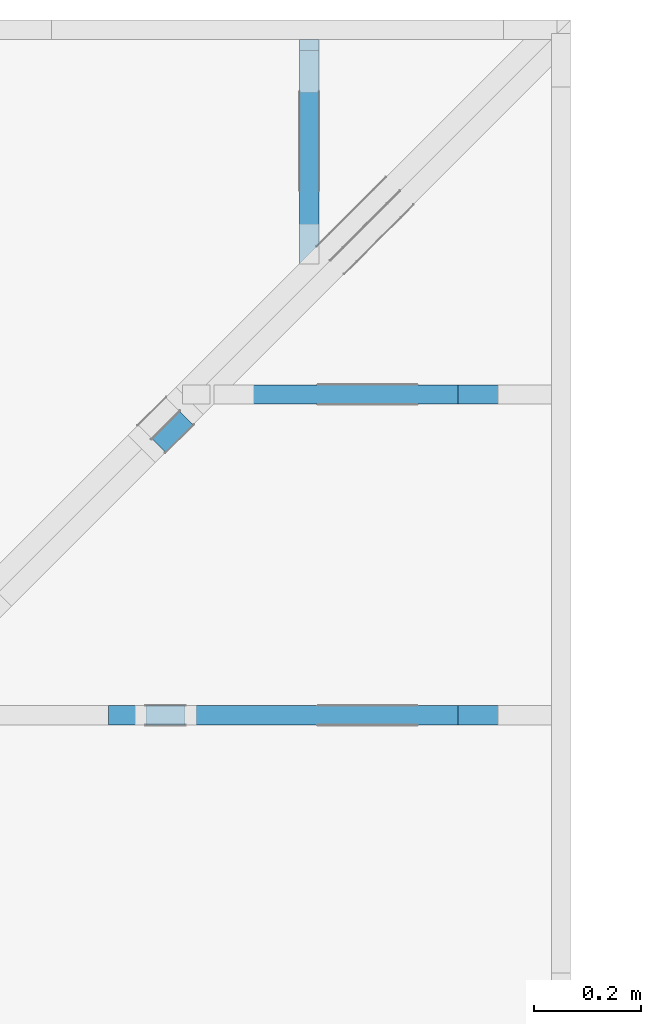
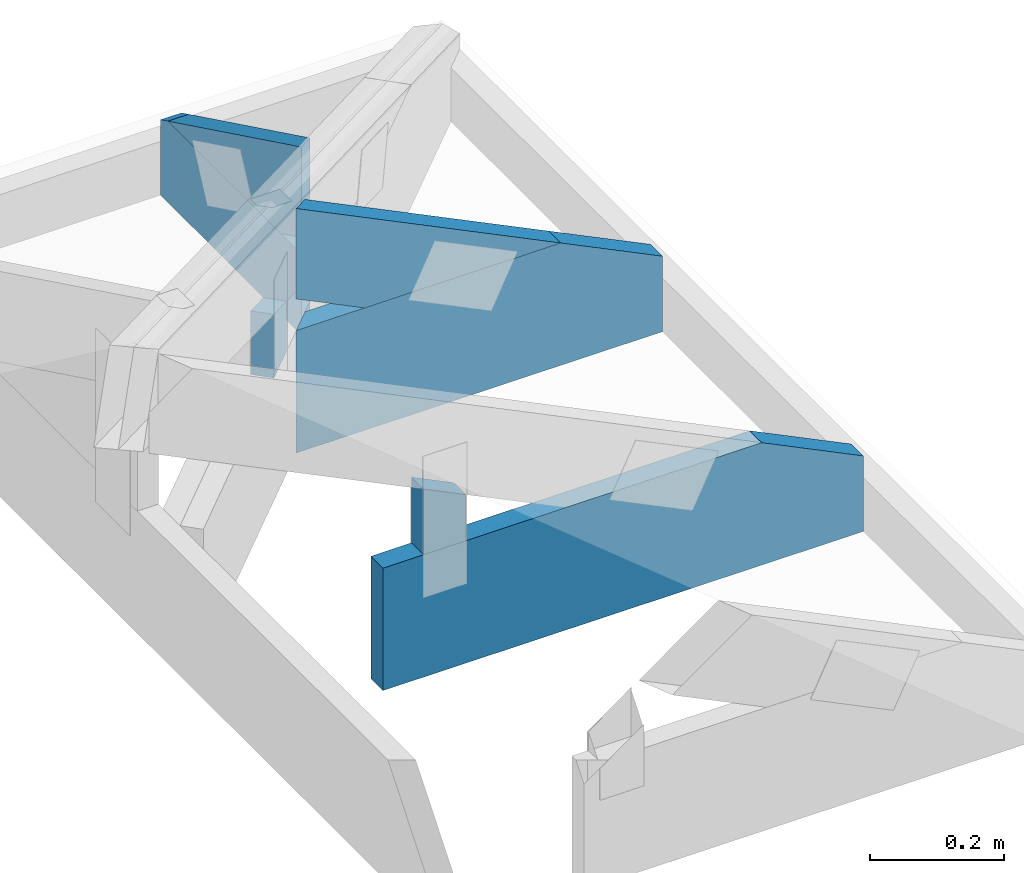
# One storey, part 53 of 159: 7 members, 4 elements without a shape of their own.
"""IFC2X3 building model written with IfcOpenShell, lengths in millimetres."""

from ifc_helpers import new_model, si_unit, frame, origin, origin_with_axes, origin_2d, place, context, project, spatial, faceted_brep, element, aggregate, save


model = new_model("IFC2X3")

# Units and contexts
model_context = context("Model", 3, precision=1e-05, world=origin())
plan_context = context("Plan", 2, precision=1e-05, world=origin_2d())
ifc_project = project(units=[si_unit("LENGTHUNIT", "METRE", prefix="MILLI"), si_unit("AREAUNIT", "SQUARE_METRE"), si_unit("VOLUMEUNIT", "CUBIC_METRE"), si_unit("SOLIDANGLEUNIT", "STERADIAN"), si_unit("PLANEANGLEUNIT", "RADIAN"), si_unit("MASSUNIT", "GRAM"), si_unit("TIMEUNIT", "SECOND"), si_unit("THERMODYNAMICTEMPERATUREUNIT", "DEGREE_CELSIUS"), si_unit("LUMINOUSINTENSITYUNIT", "LUMEN")], contexts=[model_context, plan_context])

# Site, building, storey
site_placement = place(None, origin_with_axes())
site = spatial("IfcSite", under=ifc_project, at=site_placement, CompositionType="ELEMENT")
building_placement = place(site_placement, origin_with_axes())
building = spatial("IfcBuilding", under=site, at=building_placement, Name="Plan 1", CompositionType="ELEMENT")
storey_placement = place(building_placement, origin_with_axes())
storey = spatial("IfcBuildingStorey", under=building, at=storey_placement, Name="Etasje 1", CompositionType="ELEMENT", Elevation=0.0)

# Assembly, member
assembly_1_placement = place(storey_placement, frame((19174.556818978774, 13925.455822662876, 2.204291436880279e-15), z_axis=(-0.7071067811865465, 0.7071067811865486, 6.123031769111886e-17), x_axis=(-0.7071067811865486, -0.7071067811865465, 0.0)))
assembly_1 = element("IfcElementAssembly", 1, at=assembly_1_placement, inside=storey, Name="GR3 (58)", AssemblyPlace="FACTORY", PredefinedType="TRUSS")
member_1_placement = place(assembly_1_placement, frame((1107.3371583767168, 223.0, -72.0), z_axis=(0.0, 0.0, 1.0), x_axis=(6.123031769111886e-17, 1.0, 0.0)))
member_1 = element("IfcMember", 2, at=member_1_placement, Name="GR3-D77", context=model_context, shape_type="Brep", body=[
    faceted_brep([(90.95892333984375, 73.00000017359184, 36.0), (0.0, 73.00000017359184, 36.0), (0.0, 1.7359184312226716e-07, 36.0), (116.13507080078125, 1.7359184312226716e-07, 36.0), (0.0, 73.00000017359184, 0.0), (90.95892333984375, 73.00000017359184, 1.1138887545881518e-14), (116.13507080078125, 1.7359184312226716e-07, 1.4221974560424836e-14), (0.0, 1.7359184312226716e-07, 0.0), (1.5830892152735032e-10, 0.0, 0.0), (1.583111258187872e-10, -8.577881281512834e-28, 36.0), (1.867186822366619e-10, 73.0, 36.0), (1.8671647794522503e-10, 73.0, -8.736768442928876e-31), (116.1350835837651, -2.133296418875574e-14, 1.3062241745707756e-30), (116.1350835837651, -1.912867275187546e-14, 36.0), (1.5830892152735032e-10, 2.2042914368511993e-15, 36.0), (1.5830892152735032e-10, -2.90799166753742e-26, 1.7805725364644272e-42), (90.95891506678528, 73.0, 6.675876479602264e-31), (90.95891506678528, 73.0, 36.0), (116.13508358376511, 0.0, 36.0), (116.13508358376511, 0.0, 9.055383698773292e-31), (1.8670220924832392e-10, 73.0, 0.0), (1.8670220924832392e-10, 73.0, 36.0), (90.95891506678527, 72.99999999999999, 36.0), (90.95891506678527, 73.0, 0.0)], [[[0, 1, 2, 3]], [[4, 5, 6, 7]], [[8, 9, 10, 11]], [[12, 13, 14, 15]], [[16, 17, 18, 19]], [[20, 21, 22, 23]]]),
])
aggregate(assembly_1, [member_1])

# Assembly, members
assembly_2_placement = place(storey_placement, frame((19164.01266310149, 12617.999978540158, 1.1021457184401395e-15), z_axis=(1.2246063538223773e-16, 1.0, 6.123031769111886e-17), x_axis=(-1.0, 1.2246063538223773e-16, 0.0)))
assembly_2 = element("IfcElementAssembly", 3, at=assembly_2_placement, inside=storey, Name="S44 (75)", AssemblyPlace="FACTORY", PredefinedType="TRUSS")
member_2_placement = place(assembly_2_placement, frame((828.00634765625, 223.0000000000002, -36.0), z_axis=(0.0, 0.0, 1.0), x_axis=(-1.0, -3.216285744678249e-16, 0.0)))
member_2 = element("IfcMember", 4, at=member_2_placement, Name="S44-U27", context=model_context, shape_type="Brep", body=[
    faceted_brep([(828.0063476562501, 222.99999999999994, 36.0), (1.1368683772161603e-13, 222.99999999999994, 36.0), (0.0, 1.9895196601282805e-13, 36.0), (652.8250579833984, 1.9895196601282805e-13, 36.0), (828.0063476562501, 85.44161987304682, 36.0), (1.1368683772161603e-13, 222.99999999999994, 1.392216238198645e-29), (828.0063476562501, 222.99999999999994, 1.0139818343451041e-13), (828.0063476562501, 85.44161987304682, 1.0139818343451041e-13), (652.8250579833984, 1.9895196601282805e-13, 7.994537139409316e-14), (0.0, 1.9895196601282805e-13, 0.0), (1.6124096873681992e-05, 1.9895196601282803e-13, 0.0), (1.6124096875886284e-05, 1.9895196601282803e-13, 36.0), (1.61240970022269e-05, 223.0000000000002, 36.0), (1.6124097000022608e-05, 223.0000000000002, -7.7479484577952425e-31), (652.8250519745052, 7.90339149393735e-14, -4.8392717201107054e-30), (652.8250519745052, 8.123820637625378e-14, 36.0), (1.6124096873681992e-05, 2.0115625940176347e-13, 36.0), (1.6124096873681992e-05, 1.989519679648832e-13, -1.1952495622996613e-37), (828.0063476562501, 85.44162681161856, -1.8185901092458115e-29), (828.0063476562501, 85.44162681161856, 36.0), (652.8250519745052, 2.2737367544323206e-13, 36.0), (652.8250519745052, 2.2737367544323206e-13, -1.4429853754734475e-29), (828.0063476562501, 222.99999999999994, 0.0), (828.0063476562501, 222.99999999999994, 36.0), (828.0063476562501, 85.44162681161828, 36.0), (828.0063476562501, 85.44162681161828, 0.0), (1.612409698736883e-05, 223.0000000000002, 0.0), (1.612409698736883e-05, 223.0000000000002, 36.0), (828.0063476562501, 222.99999999999997, 36.0), (828.0063476562501, 222.99999999999997, 1.5777218104420236e-30)], [[[0, 1, 2, 3, 4]], [[5, 6, 7, 8, 9]], [[10, 11, 12, 13]], [[14, 15, 16, 17]], [[18, 19, 20, 21]], [[22, 23, 24, 25]], [[26, 27, 28, 29]]]),
])
member_3_placement = place(assembly_2_placement, frame((758.0000000000036, 222.99999999999997, -36.0), z_axis=(0.0, 0.0, 1.0), x_axis=(6.123031769111886e-17, 1.0, 0.0)))
member_3 = element("IfcMember", 5, at=member_3_placement, Name="S44-D76", context=model_context, shape_type="Brep", body=[
    faceted_brep([(83.99011230468753, 73.00000000000364, 36.0), (0.0, 73.00000000000364, 36.0), (2.842170943040401e-14, 3.637978807091713e-12, 36.0), (119.5945739746094, 3.637978807091713e-12, 36.0), (0.0, 73.00000000000364, 0.0), (83.99011230468753, 73.00000000000364, 1.0285482518657537e-14), (119.5945739746094, 3.637978807091713e-12, 1.46456275171987e-14), (2.842170943040401e-14, 3.637978807091713e-12, 3.4805405954966126e-30), (2.842170943040401e-14, 0.0, 0.0), (3.0626000867284286e-14, 7.089631125554376e-31, 36.0), (7.14711493113307e-15, 73.0, 36.0), (4.9428234942527904e-15, 73.0, -3.026506528442246e-31), (119.59458813170059, -2.196844387632762e-14, 1.345134797727055e-30), (119.59458813170059, -1.9764152439447342e-14, 36.0), (2.842170943040401e-14, 2.204291436880274e-15, 36.0), (2.842170943040401e-14, -5.220810893244919e-30, 3.1967190959864043e-46), (83.99010916625954, 73.0, -7.001352389041512e-31), (83.99010916625953, 73.0, 36.0), (119.59458813170058, 0.0, 36.0), (119.59458813170059, 0.0, -9.5041350724697e-31), (0.0, 73.0, 0.0), (-1.3496946496399237e-31, 73.0, 36.0), (83.99010916625954, 72.99999999999999, 36.0), (83.99010916625954, 73.0, 0.0)], [[[0, 1, 2, 3]], [[4, 5, 6, 7]], [[8, 9, 10, 11]], [[12, 13, 14, 15]], [[16, 17, 18, 19]], [[20, 21, 22, 23]]]),
])
aggregate(assembly_2, [member_2, member_3])

assembly_3_placement = place(storey_placement, frame((19164.012663706424, 13217.999978540158, 1.1021457184401395e-15), z_axis=(3.360744850222944e-08, 0.9999999999999994, 6.123031769111886e-17), x_axis=(-0.9999999999999994, 3.360744850222944e-08, 0.0)))
assembly_3 = element("IfcElementAssembly", 6, at=assembly_3_placement, inside=storey, Name="S28 (1)", AssemblyPlace="FACTORY", PredefinedType="TRUSS")
member_4_placement = place(assembly_3_placement, frame((240.06022092491418, 89.97847895907293, -36.0), z_axis=(0.0, 0.0, 1.0), x_axis=(0.8987940462991669, 0.43837114678907757, 0.0)))
member_4 = element("IfcMember", 7, at=member_4_placement, Name="S28-O76", context=model_context, shape_type="Brep", body=[
    faceted_brep([(507.24300959543586, 148.000002648024, 2.8498062931703316e-06), (467.1893435101689, 147.99999562054933, 35.999998798621505), (395.00492120281297, 2.1444179765239824e-09, 35.99999999999997), (435.0585872880798, 4.2130437805099064e-08, 9.880712354970456e-07), (1.3254861869427259e-05, 148.00000000007122, 0.0), (1.3254861869427259e-05, 148.00000000007122, 36.00000000000001), (467.1893443095494, 148.0000000000713, 36.00000000000001), (507.2430132853795, 148.0000000000713, 3.1554436208840472e-30), (303.4449735432028, 1.5701573374826694e-09, 2.418149984808961e-30), (303.4449735432028, 1.5701573374826694e-09, 36.0), (1.8300715822761049e-06, 148.00000154251038, 36.0), (1.8300715822761049e-06, 148.00000154251038, -1.999236346418783e-31), (435.05858836803014, 2.3954438630148616e-09, 1.291082264614008e-28), (395.0049193922002, 2.395509380043368e-09, 36.0), (303.4449714246709, 2.3955261987774733e-09, 36.0), (303.4449714246709, 2.3954680392455953e-09, 9.005049696013056e-29), (467.18934655681693, 148.0000000021444, 36.0), (7.872734897773626e-06, 148.0000000021444, 36.0), (303.444977049981, 1.5701857591920998e-09, 36.0), (395.004921202813, 1.5701857591920998e-09, 36.0), (0.0, 148.00000000090228, 0.0), (507.2430114746093, 148.00000000090228, 6.211730147838035e-14), (435.0585861206054, 2.842170943040401e-14, 5.327755088482733e-14), (303.4449768066407, 2.842170943040401e-14, 3.716006466328961e-14)], [[[0, 1, 2, 3]], [[4, 5, 6, 7]], [[8, 9, 10, 11]], [[12, 13, 14, 15]], [[16, 17, 18, 19]], [[20, 21, 22, 23]]]),
])
member_5_placement = place(assembly_3_placement, frame((631.0883178710941, 222.99999999999994, -36.00000168119519), z_axis=(0.0, 0.0, 1.0), x_axis=(-1.0, 1.4547282649324256e-15, 0.0)))
member_5 = element("IfcMember", 8, at=member_5_placement, Name="S28-U29", context=model_context, shape_type="Brep", body=[
    faceted_brep([(2.8348579070003076e-05, -1.1578627768246628e-14, 2.0990520912203174e-06), (36.00002551115996, 4.213745886906756e-30, 36.00000168119529), (36.00002551115975, 223.0, 36.00000168119516), (2.8348579027036066e-05, 223.0, 2.0990521199764795e-06), (455.90700793303506, -8.374599269710144e-14, 1.6811951866202435e-06), (455.90700793303506, -8.154170126022116e-14, 36.00000168119519), (36.00002551116006, -4.408587456989748e-15, 36.00000168119519), (2.932585732651205e-05, -5.283954566622738e-21, 1.6811951866202435e-06), (2.7930724172620103e-05, 222.99999999999994, 1.6811951866202435e-06), (36.00002411602691, 222.99999999999994, 36.00000168119519), (631.0883458018179, 222.99999999999991, 36.00000168119519), (631.0883458018179, 222.99999999999991, 1.6811951866202435e-06), (631.088317871145, 85.44162681230284, 1.6811951866202435e-06), (631.088317871145, 85.44162681230284, 36.00000168119519), (455.9070276302664, 2.6546236142621638e-06, 36.00000168119519), (455.9070276302664, 2.6546236142621638e-06, 1.6811951866202435e-06), (631.0883178711767, 222.99999997399627, 1.1104684602969428e-06), (631.0883178711767, 222.99999997399627, 36.00000168119519), (631.0883178711767, 85.44162239046818, 36.00000226088838), (631.0883178711767, 85.44162239046818, 1.9500641577063412e-27), (631.0883433822535, 223.00000000000085, 36.00000168119519), (36.00002551115972, 223.00000000000085, 36.00000168119519), (36.00002551116006, 0.0, 36.00000168119519), (455.9070079330347, 0.0, 36.00000168119519), (631.0883433822535, 85.44161987304688, 36.00000168119519), (0.0, 222.99999999999994, 1.6811951866202435e-06), (631.0883178710938, 222.99999999999994, 1.68119526390372e-06), (631.0883178711449, 85.44161987304773, 1.68119526390372e-06), (455.9070281982422, 8.526512829121202e-13, 1.6811952424509078e-06), (0.0, 8.526512829121202e-13, 1.6811951866202435e-06)], [[[0, 1, 2, 3]], [[4, 5, 6, 7]], [[8, 9, 10, 11]], [[12, 13, 14, 15]], [[16, 17, 18, 19]], [[20, 21, 22, 23, 24]], [[25, 26, 27, 28, 29]]]),
])
aggregate(assembly_3, [member_4, member_5])

assembly_4_placement = place(storey_placement, frame((18693.022261405276, 13863.999978522186, 1.1021457184401395e-15), z_axis=(-1.0, -5.322035539589813e-11, 6.123031769111886e-17), x_axis=(5.322035539589813e-11, -1.0, 0.0)))
assembly_4 = element("IfcElementAssembly", 9, at=assembly_4_placement, inside=storey, Name="S43 (1)", AssemblyPlace="FACTORY", PredefinedType="TRUSS")
member_6_placement = place(assembly_4_placement, frame((86.28742872533536, 14.978476978094285, -36.00000021918814), z_axis=(0.0, 0.0, 1.0), x_axis=(0.8987940462991671, 0.4383711467890772, 0.0)))
member_6 = element("IfcMember", 10, at=member_6_placement, Name="S43-O77", context=model_context, shape_type="Brep", body=[
    faceted_brep([(443.56125500317376, 147.99999481863756, 36.000003246492724), (371.3768310546875, 6.654232720393338e-10, 36.00000021918814), (331.3231611135975, 3.1973969782939093e-07, 0.0), (403.50758506208376, 147.99999513771184, 3.0273045581452607e-06), (5.382786270047291e-06, 147.9999999999441, 2.1918813786214741e-07), (5.382786270047291e-06, 147.99999999994407, 36.00000021918814), (443.5612541620832, 147.99999999994404, 36.00000021918814), (403.50758518625315, 147.99999999994407, 2.1918813786214741e-07), (1.5949890268984745e-05, 148.00000000056346, 2.1918813786214937e-07), (403.5075843092653, 148.00000000056346, 2.1918818727594256e-07), (331.3231589552614, 0.0, 2.1918817843619198e-07), (303.4449774977419, 0.0, 2.1918817502221216e-07), (303.44497806285074, 1.2309442354307976e-09, 2.1918813786214741e-07), (303.44497806285074, 1.2309442354307976e-09, 36.00000021918814), (6.349719392062525e-06, 148.00000154217122, 36.00000021918814), (6.349719392062525e-06, 148.00000154217122, 2.1918813786214741e-07), (371.3768301778352, 9.989002287874057e-10, 36.00000021918814), (303.44497783713695, 9.989127072541062e-10, 36.00000021918814), (303.44497783713695, 9.989105029626693e-10, 2.1918813786214741e-07), (331.32316120200505, 9.98905381992597e-10, 2.1918813786214741e-07), (443.5612564086915, 148.0000000006655, 36.00000021918814), (0.0, 148.0000000006655, 36.00000021918814), (303.4449768066407, 1.23111476568738e-09, 36.00000021918814), (371.3768310546875, 1.23111476568738e-09, 36.00000021918814)], [[[0, 1, 2, 3]], [[4, 5, 6, 7]], [[8, 9, 10, 11]], [[12, 13, 14, 15]], [[16, 17, 18, 19]], [[20, 21, 22, 23]]]),
])
member_7_placement = place(assembly_4_placement, frame((420.07871341427915, 148.00000002737494, -36.00000168266722), z_axis=(0.0, 0.0, 1.0), x_axis=(-1.0, 2.342906684632551e-15, 0.0)))
member_7 = element("IfcMember", 11, at=member_7_placement, Name="S43-U42", context=model_context, shape_type="Brep", body=[
    faceted_brep([(36.00000107209837, 2.737502938677139e-08, 6.105694048130772e-07), (4.676511622392354e-09, 2.7374937872082225e-08, 36.00000168266722), (4.676152798310795e-09, 148.0000000273749, 36.0000016826672), (36.00000107209836, 148.00000002737502, 6.105690459889956e-07), (398.67019653787963, 2.7374864639973968e-08, 1.6826672180059177e-06), (398.67019653787963, 2.7374866844265405e-08, 36.00000168266722), (4.676508069678675e-09, 2.7374940076373767e-08, 36.00000168266722), (36.00000000467651, 2.737493125920802e-08, 1.6826672180059177e-06), (36.0, 148.00000002737502, 1.6826672224145005e-06), (420.0787048339847, 148.00000002737502, 1.6826672694490227e-06), (420.0787048339847, 10.441626576142113, 1.6826672694490227e-06), (398.67019653320347, 2.737587578849343e-08, 1.6826672668273232e-06), (36.00000000000034, 2.737587578849343e-08, 1.6826672224145005e-06), (-1.349694712725672e-31, 148.00000002737502, 36.00000168266722), (420.0787048339844, 148.000000027375, 36.00000168266722), (420.0787048339844, 148.000000027375, 1.6826672180059177e-06), (36.0, 148.00000002737502, 1.6826672180059177e-06), (420.07871342048736, 10.441626833668238, 1.6826672180059177e-06), (420.07871342048736, 10.441626833668238, 36.00000168266722), (398.6702058098774, -5.684341886080802e-14, 36.00000168266722), (398.6702058098774, -5.684341886080802e-14, 1.6826672180059177e-06), (420.07871342095865, 148.0000000017566, 1.1119404845771896e-06), (420.07871342095865, 148.0000000017566, 36.00000168266722), (420.07871342095865, 10.441622417843234, 36.00000226088839), (420.07871342095865, 10.441622417843234, 2.885653191298461e-26), (420.0787134142788, 148.0000069606214, 36.00000168266722), (8.586502985963307e-06, 148.0000069606214, 36.00000168266722), (8.586502985963307e-06, 2.8490117642832047e-07, 36.00000168266722), (398.6702051197061, 2.8490117642832047e-07, 36.00000168266722), (420.07871342048736, 10.441626833668266, 36.00000168266722)], [[[0, 1, 2, 3]], [[4, 5, 6, 7]], [[8, 9, 10, 11, 12]], [[13, 14, 15, 16]], [[17, 18, 19, 20]], [[21, 22, 23, 24]], [[25, 26, 27, 28, 29]]]),
])
aggregate(assembly_4, [member_6, member_7])

save(model, "model.ifc")
